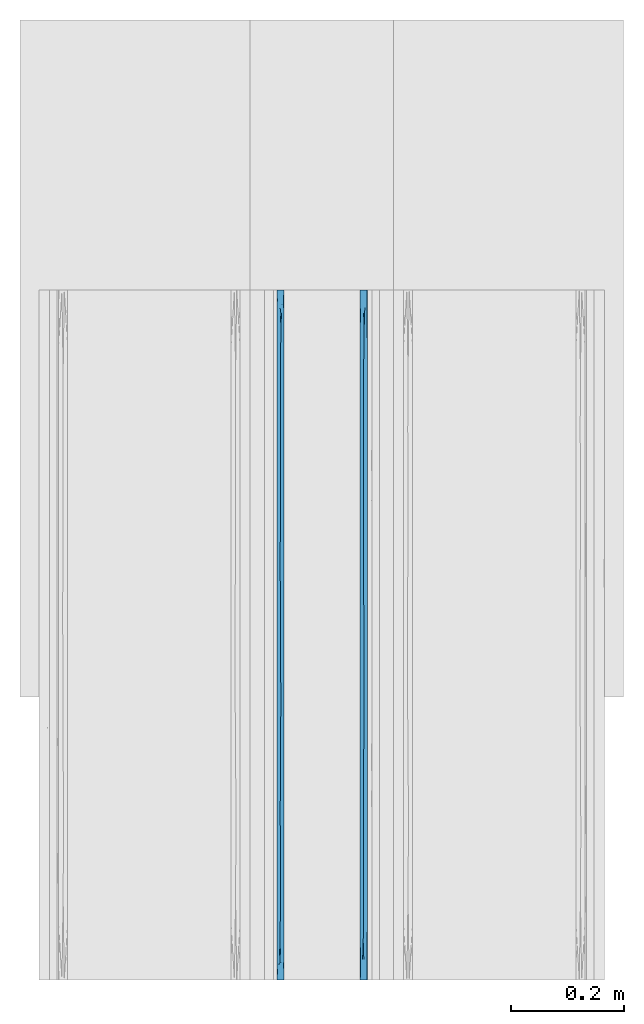
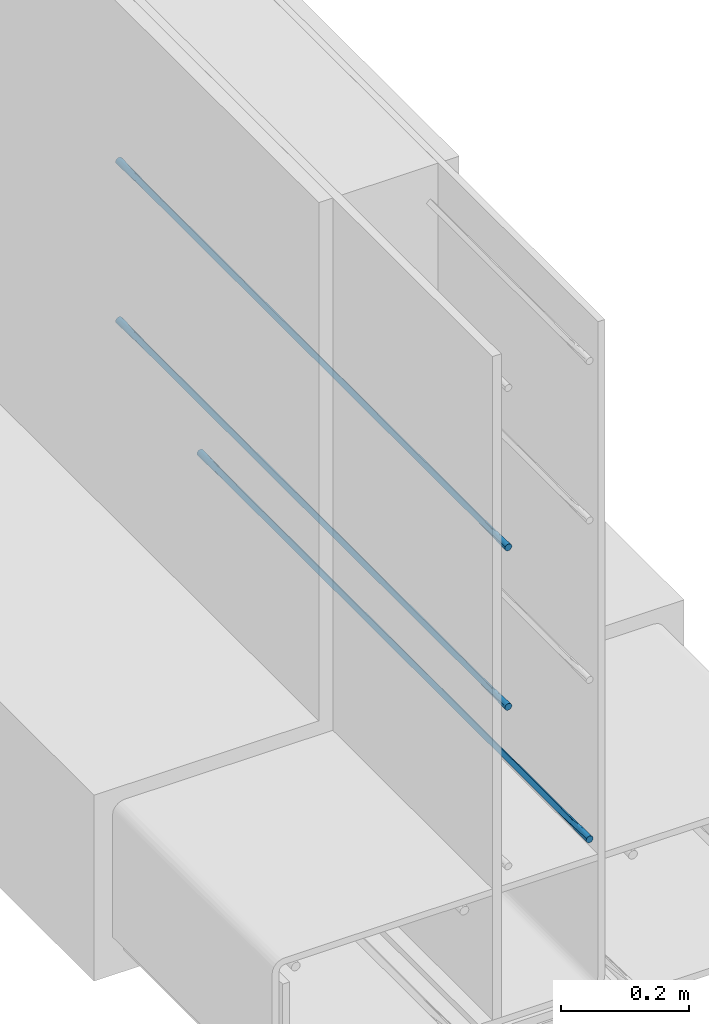
# One storey, part 8 of 10: 3 walls.
"""IFC2X3 building model written with IfcOpenShell, lengths in feet."""

from ifc_helpers import new_model, entity, si_unit, converted_unit, derived_unit, direction, frame, origin, place, context, subcontext, project, spatial, faceted_brep, material, type_object, element, save


model = new_model("IFC2X3")

# Units and contexts
model_context = context("Model", 3, precision=0.0001, world=origin(), true_north=direction((6.12303176911189e-17, 1.0)))
body_context = subcontext(model_context, "Body", "Model", "MODEL_VIEW")
ifc_project = project(units=[converted_unit("LENGTHUNIT", "FOOT", entity("IfcRatioMeasure", 0.3048), si_unit("LENGTHUNIT", "METRE"), dimensions=[1, 0, 0, 0, 0, 0, 0]), converted_unit("AREAUNIT", "SQUARE FOOT", entity("IfcRatioMeasure", 0.09290304), si_unit("AREAUNIT", "SQUARE_METRE"), dimensions=[2, 0, 0, 0, 0, 0, 0]), converted_unit("VOLUMEUNIT", "CUBIC FOOT", entity("IfcRatioMeasure", 0.028316846592), si_unit("VOLUMEUNIT", "CUBIC_METRE"), dimensions=[3, 0, 0, 0, 0, 0, 0]), converted_unit("PLANEANGLEUNIT", "DEGREE", entity("IfcRatioMeasure", 0.0174532925199433), si_unit("PLANEANGLEUNIT", "RADIAN"), dimensions=[0, 0, 0, 0, 0, 0, 0]), si_unit("MASSUNIT", "GRAM", prefix="KILO"), derived_unit("MASSDENSITYUNIT", [(si_unit("MASSUNIT", "GRAM", prefix="KILO"), 1), (si_unit("LENGTHUNIT", "METRE"), -3)]), si_unit("TIMEUNIT", "SECOND"), si_unit("FREQUENCYUNIT", "HERTZ"), si_unit("THERMODYNAMICTEMPERATUREUNIT", "DEGREE_CELSIUS"), derived_unit("THERMALTRANSMITTANCEUNIT", [(si_unit("MASSUNIT", "GRAM", prefix="KILO"), 1), (si_unit("THERMODYNAMICTEMPERATUREUNIT", "KELVIN"), -1), (si_unit("TIMEUNIT", "SECOND"), -3)]), derived_unit("VOLUMETRICFLOWRATEUNIT", [(si_unit("LENGTHUNIT", "METRE"), 3), (si_unit("TIMEUNIT", "SECOND"), -1)]), si_unit("ELECTRICCURRENTUNIT", "AMPERE"), si_unit("ELECTRICVOLTAGEUNIT", "VOLT"), si_unit("POWERUNIT", "WATT"), si_unit("FORCEUNIT", "NEWTON", prefix="KILO"), si_unit("ILLUMINANCEUNIT", "LUX"), si_unit("LUMINOUSFLUXUNIT", "LUMEN"), si_unit("LUMINOUSINTENSITYUNIT", "CANDELA"), derived_unit("USERDEFINED", [(si_unit("MASSUNIT", "GRAM", prefix="KILO"), -1), (si_unit("LENGTHUNIT", "METRE"), -2), (si_unit("TIMEUNIT", "SECOND"), 3), (si_unit("LUMINOUSFLUXUNIT", "LUMEN"), 1)]), derived_unit("LINEARVELOCITYUNIT", [(si_unit("LENGTHUNIT", "METRE"), 1), (si_unit("TIMEUNIT", "SECOND"), -1)]), si_unit("PRESSUREUNIT", "PASCAL"), derived_unit("USERDEFINED", [(si_unit("LENGTHUNIT", "METRE"), -2), (si_unit("MASSUNIT", "GRAM", prefix="KILO"), 1), (si_unit("TIMEUNIT", "SECOND"), -2)])], contexts=[model_context])

# Site, building, storey
site_placement = place(None, origin())
site = spatial("IfcSite", under=ifc_project, at=site_placement, CompositionType="ELEMENT")
building_placement = place(site_placement, origin())
building = spatial("IfcBuilding", under=site, at=building_placement, CompositionType="ELEMENT")
storey_placement = place(building_placement, frame((0.0, 0.0, 11.2604166666667)))
storey = spatial("IfcBuildingStorey", under=building, at=storey_placement, Name="2ND FLOOR", CompositionType="ELEMENT", Elevation=11.2604166666667)

# Walls
ifc_material = material()
wall_type_1 = type_object("IfcWallType", Name="Generic Models 1", PredefinedType="NOTDEFINED", material=ifc_material)
wall_1_placement = place(storey_placement, frame((1429.41837203322, 0.249999999995826, 4.90503341074841), z_axis=(0.0, 0.0, 1.0), x_axis=(0.0, 1.0, 0.0)))
element("IfcWall", 1, at=wall_1_placement, inside=storey, type_object=wall_type_1, material=ifc_material, Name="Generic Models 225:Generic Models 1", ObjectType="Generic Models 225:Generic Models 1", context=body_context, shape_type="Brep", body=[
    faceted_brep([(4.0, -0.0262253967728157, 0.0409567880476871), (4.0, -0.03125, 0.0388755292455087), (4.0, -0.0355647246078661, 0.0355647246080508), (4.0, -0.038875529245388, 0.03125), (4.0, -0.0409567880476516, 0.0262253967729684), (4.0, -0.0416666666665151, 0.0208333333333321), (4.0, -0.0409567880476516, 0.0154412698936959), (4.0, -0.038875529245388, 0.0104166666666643), (4.0, -0.0355647246078661, 0.00610194205861347), (4.0, -0.03125, 0.00279113742115555), (4.0, -0.0262253967728157, 0.0007098786189772), (4.0, -0.0208333333332575, 0.0), (4.0, -0.0154412698936994, 0.0007098786189772), (4.0, -0.0104166666665151, 0.00279113742115555), (4.0, -0.006101942058649, 0.00610194205861347), (4.0, -0.00279113742112713, 0.0104166666666643), (4.0, -0.000709878618863513, 0.0154412698936959), (4.0, 0.0, 0.0208333333333321), (4.0, -0.000709878618863513, 0.0262253967729684), (4.0, -0.00279113742112713, 0.03125), (4.0, -0.006101942058649, 0.0355647246080508), (4.0, -0.0104166666665151, 0.0388755292455087), (4.0, -0.0154412698936994, 0.0409567880476871), (4.0, -0.0208333333332575, 0.0416666666666643), (0.0, -0.0262253967728157, 0.000709878618984305), (0.0, -0.03125, 0.00279113742116266), (0.0, -0.0355647246078661, 0.00610194205862058), (0.0, -0.038875529245388, 0.0104166666666714), (0.0, -0.0409567880476516, 0.015441269893703), (0.0, -0.0416666666665151, 0.0208333333333393), (0.0, -0.0409567880476516, 0.0262253967729755), (0.0, -0.038875529245388, 0.0312500000000071), (0.0, -0.0355647246078661, 0.0355647246080579), (0.0, -0.03125, 0.0388755292455159), (0.0, -0.0262253967728157, 0.0409567880476942), (0.0, -0.0208333333332575, 0.0416666666666714), (0.0, -0.0154412698936994, 0.0409567880476942), (0.0, -0.0104166666665151, 0.0388755292455159), (0.0, -0.006101942058649, 0.0355647246080579), (0.0, -0.00279113742112713, 0.0312500000000071), (0.0, -0.000709878618863513, 0.0262253967729755), (0.0, 0.0, 0.0208333333333393), (0.0, -0.000709878618863513, 0.015441269893703), (0.0, -0.00279113742112713, 0.0104166666666714), (0.0, -0.006101942058649, 0.00610194205862058), (0.0, -0.0104166666665151, 0.00279113742116266), (0.0, -0.0154412698936994, 0.000709878618984305), (0.0, -0.0208333333332575, 0.0), (2.14388402114763, -0.0200322252712795, 1.54082770080777e-05), (1.8749999873482, -0.0201164472750861, 1.23378682417297e-05), (2.0, 0.0, 0.0208333333333357), (0.2209945797568, -0.0235526290068719, 0.000178232055045413), (3.78349365025041, -0.0181140376355415, 0.000178232058182459), (0.288675181168509, -0.0416666666665151, 0.0208333333333393), (2.55662427510468, -0.0416666666667425, 0.0208333333333357), (2.39350545093993, -0.0230795128859427, 0.000121441696034452), (2.72964779378728, -0.0208333333494011, 0.0), (3.71132487914723, -0.0416666666665151, 0.0208333333333321), (0.959427115258349, -0.0225483860315308, 7.07137486202214e-05), (0.78867513369125, 0.0, 0.0208333333333357), (0.845299480274044, 0.0, 0.0208333333333393), (1.0, 0.0, 0.0208333333333393), (1.05662434259908, 0.0, 0.0208333333333357), (1.25, 0.0, 0.0208333333333357), (1.75, 0.0, 0.0208333333333357), (1.62498580610317, -0.0185830665252524, 0.000121885361959784), (3.71132486630875, 0.0, 0.0208333333333321), (0.28867513369125, 0.0, 0.0208333333333393), (0.577350267382501, 0.0, 0.0208333333333357), (0.711324858555642, -0.0208333333287101, 0.0), (0.44198915950752, -0.0208333333268911, 0.0), (3.13397456595189, 0.0, 0.0208333333333321), (3.42264969964314, 0.0, 0.0208333333333321), (3.27831213705374, -0.0208333333389419, 0.0), (2.98963700310718, -0.0208333333653172, 0.0), (2.63397456595189, 0.0, 0.0208333333333357), (2.84529943226064, 0.0, 0.0208333333333357), (3.56698727175129, -0.0208333335056068, 0.0), (3.42264975829447, -0.0416666666665151, 0.0208333333333321), (3.1339746374417, -0.0416666666665151, 0.0208333333333357), (2.84529945627319, -0.0416666666662877, 0.0208333333333321), (2.6339745906388, -0.0416666666665151, 0.0208333333333357), (0.845299486431061, -0.0416666666665151, 0.0208333333333393), (0.788675136453734, -0.0416666666665151, 0.0208333333333357), (0.577350302021276, -0.0416666666665151, 0.0208333333333357), (1.97927407112088, 0.0, 0.0208333333333357), (1.97927403339915, -0.0416666666665151, 0.0208333333333357), (2.26794915425192, -0.0416666666662877, 0.0208333333333357), (2.21132486354627, -0.0416666666665151, 0.0208333333333357), (2.0, -0.0416666666665151, 0.0208333333333357), (2.21132486630875, 0.0, 0.0208333333333357), (2.26794921266759, 0.0, 0.0208333333333357), (2.42264969964314, 0.0, 0.0208333333333357), (2.55662432324038, 0.0, 0.0208333333333357), (1.75, -0.0416666666665151, 0.0208333333333357), (1.69059891254638, -0.0416666666665151, 0.0208333333333357), (1.47927402585968, -0.0416666666665151, 0.0208333333333357), (1.3749999905963, -0.0202049447002537, 9.47909105519784e-06), (2.42264972709253, -0.0416666666665151, 0.0208333333333357), (1.26794920492411, 0.0, 0.0208333333333357), (1.47927406724915, 0.0, 0.0208333333333357), (1.5, 0.0, 0.0208333333333357), (1.26794919948872, -0.0416666666665151, 0.0208333333333357), (1.25, -0.0416666666665151, 0.0208333333333357), (1.05662437311776, -0.0416666666665151, 0.0208333333333357), (1.0, -0.0416666666667425, 0.0208333333333393), (1.5, -0.0416666666665151, 0.0208333333333357), (1.69059892957418, 0.0, 0.0208333333333357), (2.14388402115656, -0.0216344413906882, 0.0416512583898339), (1.87499998744159, -0.0215502193923385, 0.0416543287983941), (0.220994579714599, -0.0181140376603253, 0.0414884346117397), (3.78349365012031, -0.0235526293449766, 0.0414884345671211), (2.3935054510086, -0.0185871537623825, 0.0415452249686439), (2.72964779341247, -0.0208333333278006, 0.0416666666666679), (0.959427115233259, -0.0191182806272536, 0.0415959529174224), (1.62498580618022, -0.023083600129894, 0.0415447813059444), (0.711324858513196, -0.0208333333348492, 0.0416666666666714), (0.441989159426871, -0.0208333333353039, 0.0416666666666714), (3.27831213726184, -0.0208333333314386, 0.0416666666666679), (2.9896370028857, -0.020833333322571, 0.0416666666666679), (3.56698727186825, -0.0208333332750499, 0.0416666666666679), (1.37499999066007, -0.0214617219517095, 0.0416571875760567)], [[[0, 1, 2, 3, 4, 5, 6, 7, 8, 9, 10, 11, 12, 13, 14, 15, 16, 17, 18, 19, 20, 21, 22, 23]], [[24, 25, 26, 27, 28, 29, 30, 31, 32, 33, 34, 35, 36, 37, 38, 39, 40, 41, 42, 43, 44, 45, 46, 47]], [[48, 49, 50]], [[24, 47, 51]], [[52, 9, 8]], [[27, 53, 28]], [[54, 55, 56]], [[51, 25, 24]], [[57, 7, 6]], [[57, 8, 7]], [[52, 13, 12]], [[6, 5, 57]], [[29, 28, 53]], [[58, 59, 60, 61, 62, 63]], [[64, 49, 65]], [[52, 14, 13]], [[66, 17, 16]], [[42, 41, 67]], [[42, 67, 43]], [[68, 59, 69, 70, 67]], [[71, 72, 73, 74, 56, 75, 76]], [[66, 77, 72]], [[78, 79, 80, 81, 54, 56, 74, 73]], [[69, 82, 83, 84, 53, 70]], [[78, 77, 57]], [[77, 52, 57]], [[49, 64, 85, 50]], [[48, 86, 49]], [[15, 66, 16]], [[47, 46, 51]], [[14, 52, 15]], [[70, 53, 51]], [[82, 69, 58]], [[69, 59, 58]], [[51, 26, 25]], [[44, 43, 67]], [[10, 52, 11]], [[45, 51, 46]], [[67, 70, 51]], [[44, 51, 45]], [[51, 27, 26]], [[51, 44, 67]], [[57, 52, 8]], [[48, 87, 88, 89, 86]], [[9, 52, 10]], [[55, 90, 91, 92, 93, 75]], [[53, 27, 51]], [[49, 86, 94, 95]], [[90, 55, 48]], [[73, 72, 77]], [[12, 11, 52]], [[73, 77, 78]], [[77, 66, 52]], [[66, 15, 52]], [[87, 48, 55]], [[55, 75, 56]], [[65, 96, 97]], [[55, 54, 98, 87]], [[97, 63, 99, 100, 101]], [[58, 102, 103, 104, 105, 82]], [[63, 97, 58]], [[97, 101, 65]], [[65, 95, 106, 96]], [[65, 101, 107, 64]], [[95, 65, 49]], [[102, 58, 97]], [[96, 102, 97]], [[48, 50, 90]], [[108, 109, 89]], [[36, 35, 110]], [[111, 21, 20]], [[39, 67, 40]], [[93, 112, 113]], [[110, 37, 36]], [[66, 19, 18]], [[66, 20, 19]], [[111, 1, 0]], [[18, 17, 66]], [[41, 40, 67]], [[114, 83, 82, 105, 104, 103]], [[94, 109, 115]], [[111, 2, 1]], [[57, 5, 4]], [[30, 29, 53]], [[30, 53, 31]], [[84, 83, 116, 117, 53]], [[79, 78, 118, 119, 113, 81, 80]], [[116, 83, 114]], [[72, 71, 76, 75, 93, 113, 119, 118]], [[116, 60, 59, 68, 67, 117]], [[72, 118, 120, 66]], [[120, 111, 66]], [[109, 94, 86, 89]], [[108, 85, 109]], [[3, 57, 4]], [[2, 111, 3]], [[34, 110, 35]], [[117, 67, 110]], [[60, 116, 114]], [[57, 120, 118, 78]], [[110, 38, 37]], [[32, 31, 53]], [[22, 111, 23]], [[33, 110, 34]], [[53, 117, 110]], [[32, 110, 33]], [[110, 39, 38]], [[110, 32, 53]], [[66, 111, 20]], [[108, 91, 90, 50, 85]], [[21, 111, 22]], [[112, 88, 87, 98, 54, 81]], [[67, 39, 110]], [[109, 85, 64, 107]], [[88, 112, 108]], [[0, 23, 111]], [[120, 57, 111]], [[57, 3, 111]], [[91, 108, 112]], [[112, 81, 113]], [[115, 100, 121]], [[112, 93, 92, 91]], [[121, 103, 102, 96, 106]], [[114, 99, 63, 62, 61, 60]], [[103, 121, 114]], [[121, 106, 115]], [[115, 107, 101, 100]], [[115, 106, 95, 94]], [[107, 115, 109]], [[99, 114, 121]], [[100, 99, 121]], [[108, 89, 88]]]),
])
wall_type_2 = type_object("IfcWallType", Name="Generic Models 1", PredefinedType="NOTDEFINED", material=ifc_material)
wall_2_placement = place(storey_placement, frame((1429.41837203322, 0.249999999995826, 5.90503341074841), z_axis=(0.0, 0.0, 1.0), x_axis=(0.0, 1.0, 0.0)))
element("IfcWall", 2, at=wall_2_placement, inside=storey, type_object=wall_type_2, material=ifc_material, Name="Generic Models 304:Generic Models 1", ObjectType="Generic Models 304:Generic Models 1", context=body_context, shape_type="Brep", body=[
    faceted_brep([(4.0, -0.0262253967728157, 0.0409567880476871), (4.0, -0.03125, 0.0388755292455087), (4.0, -0.0355647246078661, 0.0355647246080508), (4.0, -0.038875529245388, 0.03125), (4.0, -0.0409567880476516, 0.0262253967729684), (4.0, -0.0416666666665151, 0.0208333333333321), (4.0, -0.0409567880476516, 0.0154412698936959), (4.0, -0.038875529245388, 0.0104166666666643), (4.0, -0.0355647246078661, 0.00610194205861347), (4.0, -0.03125, 0.00279113742115555), (4.0, -0.0262253967728157, 0.0007098786189772), (4.0, -0.0208333333332575, 0.0), (4.0, -0.0154412698936994, 0.0007098786189772), (4.0, -0.0104166666665151, 0.00279113742115555), (4.0, -0.006101942058649, 0.00610194205861347), (4.0, -0.00279113742112713, 0.0104166666666643), (4.0, -0.000709878618863513, 0.0154412698936959), (4.0, 0.0, 0.0208333333333321), (4.0, -0.000709878618863513, 0.0262253967729684), (4.0, -0.00279113742112713, 0.03125), (4.0, -0.006101942058649, 0.0355647246080508), (4.0, -0.0104166666665151, 0.0388755292455087), (4.0, -0.0154412698936994, 0.0409567880476871), (4.0, -0.0208333333332575, 0.0416666666666643), (0.0, -0.0262253967728157, 0.000709878618984305), (0.0, -0.03125, 0.00279113742116266), (0.0, -0.0355647246078661, 0.00610194205862058), (0.0, -0.038875529245388, 0.0104166666666714), (0.0, -0.0409567880476516, 0.015441269893703), (0.0, -0.0416666666665151, 0.0208333333333393), (0.0, -0.0409567880476516, 0.0262253967729755), (0.0, -0.038875529245388, 0.0312500000000071), (0.0, -0.0355647246078661, 0.0355647246080579), (0.0, -0.03125, 0.0388755292455159), (0.0, -0.0262253967728157, 0.0409567880476942), (0.0, -0.0208333333332575, 0.0416666666666714), (0.0, -0.0154412698936994, 0.0409567880476942), (0.0, -0.0104166666665151, 0.0388755292455159), (0.0, -0.006101942058649, 0.0355647246080579), (0.0, -0.00279113742112713, 0.0312500000000071), (0.0, -0.000709878618863513, 0.0262253967729755), (0.0, 0.0, 0.0208333333333393), (0.0, -0.000709878618863513, 0.015441269893703), (0.0, -0.00279113742112713, 0.0104166666666714), (0.0, -0.006101942058649, 0.00610194205862058), (0.0, -0.0104166666665151, 0.00279113742116266), (0.0, -0.0154412698936994, 0.000709878618984305), (0.0, -0.0208333333332575, 0.0), (2.14388402114763, -0.0200322252712795, 1.54082770080777e-05), (1.8749999873482, -0.0201164472750861, 1.23378682417297e-05), (2.0, 0.0, 0.0208333333333357), (0.2209945797568, -0.0235526290068719, 0.000178232055045413), (3.78349365025041, -0.0181140376355415, 0.000178232058182459), (0.288675181168509, -0.0416666666665151, 0.0208333333333393), (2.55662427510468, -0.0416666666667425, 0.0208333333333357), (2.39350545093993, -0.0230795128859427, 0.000121441696034452), (2.72964779378728, -0.0208333333494011, 0.0), (3.71132487914723, -0.0416666666665151, 0.0208333333333321), (0.959427115258349, -0.0225483860315308, 7.07137486202214e-05), (0.78867513369125, 0.0, 0.0208333333333393), (0.845299480274044, 0.0, 0.0208333333333393), (1.0, 0.0, 0.0208333333333393), (1.05662434259908, 0.0, 0.0208333333333393), (1.25, 0.0, 0.0208333333333357), (1.75, 0.0, 0.0208333333333357), (1.62498580610317, -0.0185830665252524, 0.000121885361959784), (3.71132486630875, 0.0, 0.0208333333333321), (0.28867513369125, 0.0, 0.0208333333333393), (0.577350267382501, 0.0, 0.0208333333333357), (0.711324858555642, -0.0208333333287101, 0.0), (0.44198915950752, -0.0208333333268911, 0.0), (3.13397456595189, 0.0, 0.0208333333333357), (3.42264969964314, 0.0, 0.0208333333333321), (3.27831213705374, -0.0208333333389419, 0.0), (2.98963700310718, -0.0208333333653172, 0.0), (2.63397456595189, 0.0, 0.0208333333333357), (2.84529943226064, 0.0, 0.0208333333333357), (3.56698727175129, -0.0208333335056068, 0.0), (3.42264975829447, -0.0416666666665151, 0.0208333333333321), (3.1339746374417, -0.0416666666665151, 0.0208333333333321), (2.84529945627319, -0.0416666666662877, 0.0208333333333357), (2.6339745906388, -0.0416666666665151, 0.0208333333333357), (0.845299486431061, -0.0416666666665151, 0.0208333333333393), (0.788675136453734, -0.0416666666665151, 0.0208333333333357), (0.577350302021276, -0.0416666666665151, 0.0208333333333393), (1.97927407112088, 0.0, 0.0208333333333357), (1.97927403339915, -0.0416666666665151, 0.0208333333333357), (2.26794915425192, -0.0416666666662877, 0.0208333333333357), (2.21132486354627, -0.0416666666665151, 0.0208333333333357), (2.0, -0.0416666666665151, 0.0208333333333357), (2.21132486630875, 0.0, 0.0208333333333357), (2.26794921266759, 0.0, 0.0208333333333357), (2.42264969964314, 0.0, 0.0208333333333357), (2.55662432324038, 0.0, 0.0208333333333357), (1.75, -0.0416666666665151, 0.0208333333333357), (1.69059891254638, -0.0416666666665151, 0.0208333333333357), (1.47927402585968, -0.0416666666665151, 0.0208333333333357), (1.3749999905963, -0.0202049447002537, 9.47909105519784e-06), (2.42264972709253, -0.0416666666665151, 0.0208333333333357), (1.26794920492411, 0.0, 0.0208333333333357), (1.47927406724915, 0.0, 0.0208333333333357), (1.5, 0.0, 0.0208333333333357), (1.26794919948872, -0.0416666666665151, 0.0208333333333357), (1.25, -0.0416666666665151, 0.0208333333333357), (1.05662437311776, -0.0416666666665151, 0.0208333333333357), (1.0, -0.0416666666667425, 0.0208333333333393), (1.5, -0.0416666666665151, 0.0208333333333357), (1.69059892957418, 0.0, 0.0208333333333357), (2.14388402115656, -0.0216344413906882, 0.0416512583898339), (1.87499998744159, -0.0215502193923385, 0.0416543287983941), (0.220994579714599, -0.0181140376603253, 0.0414884346117397), (3.78349365012031, -0.0235526293449766, 0.0414884345671211), (2.3935054510086, -0.0185871537623825, 0.0415452249686439), (2.72964779341247, -0.0208333333278006, 0.0416666666666679), (0.959427115233259, -0.0191182806272536, 0.0415959529174224), (1.62498580618022, -0.023083600129894, 0.0415447813059444), (0.711324858513196, -0.0208333333348492, 0.0416666666666714), (0.441989159426871, -0.0208333333353039, 0.0416666666666714), (3.27831213726184, -0.0208333333314386, 0.0416666666666679), (2.9896370028857, -0.020833333322571, 0.0416666666666679), (3.56698727186825, -0.0208333332750499, 0.0416666666666679), (1.37499999066007, -0.0214617219517095, 0.0416571875760567)], [[[0, 1, 2, 3, 4, 5, 6, 7, 8, 9, 10, 11, 12, 13, 14, 15, 16, 17, 18, 19, 20, 21, 22, 23]], [[24, 25, 26, 27, 28, 29, 30, 31, 32, 33, 34, 35, 36, 37, 38, 39, 40, 41, 42, 43, 44, 45, 46, 47]], [[48, 49, 50]], [[24, 47, 51]], [[52, 9, 8]], [[27, 53, 28]], [[54, 55, 56]], [[51, 25, 24]], [[57, 7, 6]], [[57, 8, 7]], [[52, 13, 12]], [[6, 5, 57]], [[29, 28, 53]], [[58, 59, 60, 61, 62, 63]], [[64, 49, 65]], [[52, 14, 13]], [[66, 17, 16]], [[42, 41, 67]], [[42, 67, 43]], [[68, 59, 69, 70, 67]], [[71, 72, 73, 74, 56, 75, 76]], [[66, 77, 72]], [[78, 79, 80, 81, 54, 56, 74, 73]], [[69, 82, 83, 84, 53, 70]], [[78, 77, 57]], [[77, 52, 57]], [[49, 64, 85, 50]], [[48, 86, 49]], [[15, 66, 16]], [[47, 46, 51]], [[14, 52, 15]], [[70, 53, 51]], [[82, 69, 58]], [[69, 59, 58]], [[51, 26, 25]], [[44, 43, 67]], [[10, 52, 11]], [[45, 51, 46]], [[67, 70, 51]], [[44, 51, 45]], [[51, 27, 26]], [[51, 44, 67]], [[57, 52, 8]], [[48, 87, 88, 89, 86]], [[9, 52, 10]], [[55, 90, 91, 92, 93, 75]], [[53, 27, 51]], [[49, 86, 94, 95]], [[90, 55, 48]], [[73, 72, 77]], [[12, 11, 52]], [[73, 77, 78]], [[77, 66, 52]], [[66, 15, 52]], [[87, 48, 55]], [[55, 75, 56]], [[65, 96, 97]], [[55, 54, 98, 87]], [[97, 63, 99, 100, 101]], [[58, 102, 103, 104, 105, 82]], [[63, 97, 58]], [[97, 101, 65]], [[65, 95, 106, 96]], [[65, 101, 107, 64]], [[95, 65, 49]], [[102, 58, 97]], [[96, 102, 97]], [[48, 50, 90]], [[108, 109, 89]], [[36, 35, 110]], [[111, 21, 20]], [[39, 67, 40]], [[93, 112, 113]], [[110, 37, 36]], [[66, 19, 18]], [[66, 20, 19]], [[111, 1, 0]], [[18, 17, 66]], [[41, 40, 67]], [[114, 83, 82, 105, 104, 103]], [[94, 109, 115]], [[111, 2, 1]], [[57, 5, 4]], [[30, 29, 53]], [[30, 53, 31]], [[84, 83, 116, 117, 53]], [[79, 78, 118, 119, 113, 81, 80]], [[116, 83, 114]], [[72, 71, 76, 75, 93, 113, 119, 118]], [[116, 60, 59, 68, 67, 117]], [[72, 118, 120, 66]], [[120, 111, 66]], [[109, 94, 86, 89]], [[108, 85, 109]], [[3, 57, 4]], [[2, 111, 3]], [[34, 110, 35]], [[117, 67, 110]], [[60, 116, 114]], [[57, 120, 118, 78]], [[110, 38, 37]], [[32, 31, 53]], [[22, 111, 23]], [[33, 110, 34]], [[53, 117, 110]], [[32, 110, 33]], [[110, 39, 38]], [[110, 32, 53]], [[66, 111, 20]], [[108, 91, 90, 50, 85]], [[21, 111, 22]], [[112, 88, 87, 98, 54, 81]], [[67, 39, 110]], [[109, 85, 64, 107]], [[88, 112, 108]], [[0, 23, 111]], [[120, 57, 111]], [[57, 3, 111]], [[91, 108, 112]], [[112, 81, 113]], [[115, 100, 121]], [[112, 93, 92, 91]], [[121, 103, 102, 96, 106]], [[114, 99, 63, 62, 61, 60]], [[103, 121, 114]], [[121, 106, 115]], [[115, 107, 101, 100]], [[115, 106, 95, 94]], [[107, 115, 109]], [[99, 114, 121]], [[100, 99, 121]], [[108, 89, 88]]]),
])
wall_type_3 = type_object("IfcWallType", Name="Generic Models 1", PredefinedType="NOTDEFINED", material=ifc_material)
wall_3_placement = place(storey_placement, frame((1429.90087203322, 0.249999999995825, 3.90503341074841), z_axis=(0.0, 0.0, 1.0), x_axis=(0.0, 1.0, 0.0)))
element("IfcWall", 3, at=wall_3_placement, inside=storey, type_object=wall_type_3, material=ifc_material, Name="Generic Models 43:Generic Models 1", ObjectType="Generic Models 43:Generic Models 1", context=body_context, shape_type="Brep", body=[
    faceted_brep([(4.0, -0.0262253967728157, 0.0409567880476889), (4.0, -0.03125, 0.0388755292455105), (4.0, -0.0355647246078661, 0.0355647246080544), (4.0, -0.038875529245388, 0.03125), (4.0, -0.0409567880476516, 0.0262253967729702), (4.0, -0.0416666666665151, 0.0208333333333339), (4.0, -0.0409567880476516, 0.0154412698936977), (4.0, -0.038875529245388, 0.0104166666666679), (4.0, -0.0355647246078661, 0.00610194205861347), (4.0, -0.03125, 0.00279113742115733), (4.0, -0.0262253967728157, 0.000709878618978976), (4.0, -0.0208333333332575, 0.0), (4.0, -0.0154412698936994, 0.000709878618978976), (4.0, -0.0104166666665151, 0.00279113742115733), (4.0, -0.006101942058649, 0.00610194205861347), (4.0, -0.00279113742112713, 0.0104166666666679), (4.0, -0.000709878618863513, 0.0154412698936977), (4.0, 0.0, 0.0208333333333339), (4.0, -0.000709878618863513, 0.0262253967729702), (4.0, -0.00279113742112713, 0.03125), (4.0, -0.006101942058649, 0.0355647246080544), (4.0, -0.0104166666665151, 0.0388755292455105), (4.0, -0.0154412698936994, 0.0409567880476889), (4.0, -0.0208333333332575, 0.0416666666666679), (0.0, -0.0262253967728157, 0.000709878618986082), (0.0, -0.03125, 0.00279113742116444), (0.0, -0.0355647246078661, 0.00610194205862058), (0.0, -0.038875529245388, 0.010416666666675), (0.0, -0.0409567880476516, 0.0154412698937048), (0.0, -0.0416666666665151, 0.020833333333341), (0.0, -0.0409567880476516, 0.0262253967729773), (0.0, -0.038875529245388, 0.0312500000000071), (0.0, -0.0355647246078661, 0.0355647246080615), (0.0, -0.03125, 0.0388755292455176), (0.0, -0.0262253967728157, 0.040956788047696), (0.0, -0.0208333333332575, 0.041666666666675), (0.0, -0.0154412698936994, 0.040956788047696), (0.0, -0.0104166666665151, 0.0388755292455176), (0.0, -0.006101942058649, 0.0355647246080615), (0.0, -0.00279113742112713, 0.0312500000000071), (0.0, -0.000709878618863513, 0.0262253967729773), (0.0, 0.0, 0.020833333333341), (0.0, -0.000709878618863513, 0.0154412698937048), (0.0, -0.00279113742112713, 0.010416666666675), (0.0, -0.006101942058649, 0.00610194205862058), (0.0, -0.0104166666665151, 0.00279113742116444), (0.0, -0.0154412698936994, 0.000709878618986082), (0.0, -0.0208333333332575, 0.0), (2.14388402114763, -0.0200322252712795, 1.54082770116304e-05), (1.8749999873482, -0.0201164472750861, 1.23378682452824e-05), (2.0, 0.0, 0.0208333333333375), (0.2209945797568, -0.0235526290068719, 0.000178232055045413), (3.78349365025041, -0.0181140376355415, 0.000178232058184236), (0.288675181168509, -0.0416666666665151, 0.020833333333341), (2.55662427510468, -0.0416666666667425, 0.0208333333333375), (2.39350545093993, -0.0230795128859427, 0.000121441696036229), (2.72964779378728, -0.0208333333494011, 0.0), (3.71132487914723, -0.0416666666665151, 0.0208333333333339), (0.959427115258349, -0.0225483860315308, 7.07137486237741e-05), (0.78867513369125, 0.0, 0.0208333333333393), (0.845299480274044, 0.0, 0.0208333333333393), (1.0, 0.0, 0.020833333333341), (1.05662434259908, 0.0, 0.0208333333333393), (1.25, 0.0, 0.0208333333333375), (1.75, 0.0, 0.0208333333333375), (1.62498580610317, -0.0185830665252524, 0.00012188536196156), (3.71132486630875, 0.0, 0.0208333333333339), (0.28867513369125, 0.0, 0.020833333333341), (0.5773502673825, 0.0, 0.0208333333333393), (0.711324858555642, -0.0208333333287101, 0.0), (0.44198915950752, -0.0208333333268911, 0.0), (3.13397456595189, 0.0, 0.0208333333333357), (3.42264969964314, 0.0, 0.0208333333333339), (3.27831213705374, -0.0208333333389419, 0.0), (2.98963700310718, -0.0208333333653172, 0.0), (2.63397456595189, 0.0, 0.0208333333333357), (2.84529943226064, 0.0, 0.0208333333333357), (3.56698727175129, -0.0208333335056068, 0.0), (3.42264975829447, -0.0416666666665151, 0.0208333333333339), (3.1339746374417, -0.0416666666665151, 0.0208333333333339), (2.84529945627319, -0.0416666666662877, 0.0208333333333339), (2.6339745906388, -0.0416666666665151, 0.0208333333333375), (0.845299486431061, -0.0416666666665151, 0.0208333333333393), (0.788675136453734, -0.0416666666662877, 0.0208333333333375), (0.577350302021276, -0.0416666666667425, 0.020833333333341), (1.97927407112088, 0.0, 0.0208333333333375), (1.97927403339915, -0.0416666666665151, 0.0208333333333375), (2.26794915425192, -0.0416666666662877, 0.0208333333333375), (2.21132486354627, -0.0416666666665151, 0.0208333333333375), (2.0, -0.0416666666665151, 0.0208333333333375), (2.21132486630875, 0.0, 0.0208333333333375), (2.26794921266759, 0.0, 0.0208333333333375), (2.42264969964314, 0.0, 0.0208333333333375), (2.55662432324038, 0.0, 0.0208333333333375), (1.75, -0.0416666666665151, 0.0208333333333375), (1.69059891254638, -0.0416666666665151, 0.0208333333333375), (1.47927402585968, -0.0416666666665151, 0.0208333333333375), (1.3749999905963, -0.0202049447002537, 9.47909105875056e-06), (2.42264972709253, -0.0416666666665151, 0.0208333333333375), (1.26794920492411, 0.0, 0.0208333333333375), (1.47927406724915, 0.0, 0.0208333333333375), (1.5, 0.0, 0.0208333333333375), (1.26794919948872, -0.0416666666665151, 0.0208333333333375), (1.25, -0.0416666666665151, 0.0208333333333375), (1.05662437311776, -0.0416666666665151, 0.0208333333333393), (1.0, -0.0416666666665151, 0.020833333333341), (1.5, -0.0416666666667425, 0.0208333333333375), (1.69059892957418, 0.0, 0.0208333333333393), (2.14388402115656, -0.0216344413906882, 0.0416512583898374), (1.87499998744159, -0.0215502193923385, 0.0416543287983959), (0.220994579714599, -0.0181140376603253, 0.0414884346117432), (3.78349365012031, -0.0235526293449766, 0.0414884345671229), (2.3935054510086, -0.0185871537623825, 0.0415452249686457), (2.72964779341247, -0.0208333333278006, 0.0416666666666696), (0.959427115233259, -0.0191182806272536, 0.0415959529174241), (1.62498580618022, -0.023083600129894, 0.0415447813059462), (0.711324858513196, -0.0208333333348492, 0.0416666666666732), (0.441989159426871, -0.0208333333353039, 0.0416666666666732), (3.27831213726184, -0.0208333333314386, 0.0416666666666679), (2.9896370028857, -0.020833333322571, 0.0416666666666696), (3.56698727186825, -0.0208333332750499, 0.0416666666666679), (1.37499999066007, -0.0214617219517095, 0.0416571875760585)], [[[0, 1, 2, 3, 4, 5, 6, 7, 8, 9, 10, 11, 12, 13, 14, 15, 16, 17, 18, 19, 20, 21, 22, 23]], [[24, 25, 26, 27, 28, 29, 30, 31, 32, 33, 34, 35, 36, 37, 38, 39, 40, 41, 42, 43, 44, 45, 46, 47]], [[48, 49, 50]], [[24, 47, 51]], [[52, 9, 8]], [[27, 53, 28]], [[54, 55, 56]], [[51, 25, 24]], [[57, 7, 6]], [[57, 8, 7]], [[52, 13, 12]], [[6, 5, 57]], [[29, 28, 53]], [[58, 59, 60, 61, 62, 63]], [[64, 49, 65]], [[52, 14, 13]], [[66, 17, 16]], [[42, 41, 67]], [[42, 67, 43]], [[68, 59, 69, 70, 67]], [[71, 72, 73, 74, 56, 75, 76]], [[66, 77, 72]], [[78, 79, 80, 81, 54, 56, 74, 73]], [[69, 82, 83, 84, 53, 70]], [[78, 77, 57]], [[77, 52, 57]], [[49, 64, 85, 50]], [[48, 86, 49]], [[15, 66, 16]], [[47, 46, 51]], [[14, 52, 15]], [[70, 53, 51]], [[82, 69, 58]], [[69, 59, 58]], [[51, 26, 25]], [[44, 43, 67]], [[10, 52, 11]], [[45, 51, 46]], [[67, 70, 51]], [[44, 51, 45]], [[51, 27, 26]], [[51, 44, 67]], [[57, 52, 8]], [[48, 87, 88, 89, 86]], [[9, 52, 10]], [[55, 90, 91, 92, 93, 75]], [[53, 27, 51]], [[49, 86, 94, 95]], [[90, 55, 48]], [[73, 72, 77]], [[12, 11, 52]], [[73, 77, 78]], [[77, 66, 52]], [[66, 15, 52]], [[87, 48, 55]], [[55, 75, 56]], [[65, 96, 97]], [[55, 54, 98, 87]], [[97, 63, 99, 100, 101]], [[58, 102, 103, 104, 105, 82]], [[63, 97, 58]], [[97, 101, 65]], [[65, 95, 106, 96]], [[65, 101, 107, 64]], [[95, 65, 49]], [[102, 58, 97]], [[96, 102, 97]], [[48, 50, 90]], [[108, 109, 89]], [[36, 35, 110]], [[111, 21, 20]], [[39, 67, 40]], [[93, 112, 113]], [[110, 37, 36]], [[66, 19, 18]], [[66, 20, 19]], [[111, 1, 0]], [[18, 17, 66]], [[41, 40, 67]], [[114, 83, 82, 105, 104, 103]], [[94, 109, 115]], [[111, 2, 1]], [[57, 5, 4]], [[30, 29, 53]], [[30, 53, 31]], [[84, 83, 116, 117, 53]], [[79, 78, 118, 119, 113, 81, 80]], [[116, 83, 114]], [[72, 71, 76, 75, 93, 113, 119, 118]], [[116, 60, 59, 68, 67, 117]], [[72, 118, 120, 66]], [[120, 111, 66]], [[109, 94, 86, 89]], [[108, 85, 109]], [[3, 57, 4]], [[2, 111, 3]], [[34, 110, 35]], [[117, 67, 110]], [[60, 116, 114]], [[57, 120, 118, 78]], [[110, 38, 37]], [[32, 31, 53]], [[22, 111, 23]], [[33, 110, 34]], [[53, 117, 110]], [[32, 110, 33]], [[110, 39, 38]], [[110, 32, 53]], [[66, 111, 20]], [[108, 91, 90, 50, 85]], [[21, 111, 22]], [[112, 88, 87, 98, 54, 81]], [[67, 39, 110]], [[109, 85, 64, 107]], [[88, 112, 108]], [[0, 23, 111]], [[120, 57, 111]], [[57, 3, 111]], [[91, 108, 112]], [[112, 81, 113]], [[115, 100, 121]], [[112, 93, 92, 91]], [[121, 103, 102, 96, 106]], [[114, 99, 63, 62, 61, 60]], [[103, 121, 114]], [[121, 106, 115]], [[115, 107, 101, 100]], [[115, 106, 95, 94]], [[107, 115, 109]], [[99, 114, 121]], [[100, 99, 121]], [[108, 89, 88]]]),
])

save(model, "model.ifc")
